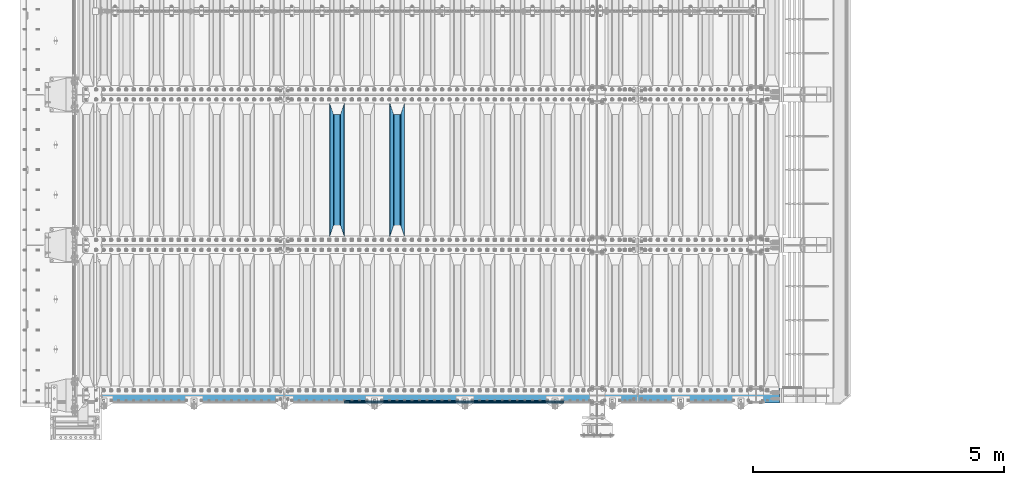
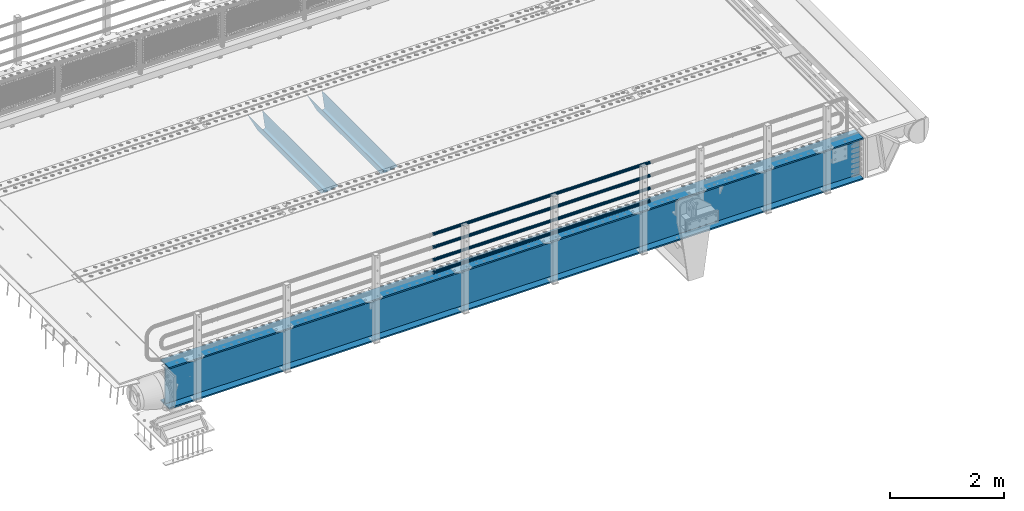
# One storey, part 100 of 219: 7 beams.
"""IFC2X3 building model written with IfcOpenShell, lengths in millimetres."""

from ifc_helpers import new_model, si_unit, frame, origin_with_axes, place, context, subcontext, project, spatial, faceted_brep, material, type_object, element, save


model = new_model("IFC2X3")

# Units and contexts
model_context = context("Model", 3, precision=1e-05, world=origin_with_axes())
body_context = subcontext(model_context, "Body", "Model", "MODEL_VIEW")
ifc_project = project(units=[si_unit("LENGTHUNIT", "METRE", prefix="MILLI"), si_unit("AREAUNIT", "SQUARE_METRE"), si_unit("VOLUMEUNIT", "CUBIC_METRE"), si_unit("MASSUNIT", "GRAM", prefix="KILO"), si_unit("TIMEUNIT", "SECOND"), si_unit("PLANEANGLEUNIT", "RADIAN"), si_unit("SOLIDANGLEUNIT", "STERADIAN"), si_unit("THERMODYNAMICTEMPERATUREUNIT", "DEGREE_CELSIUS"), si_unit("LUMINOUSINTENSITYUNIT", "LUMEN")], contexts=[model_context])

# Site, building, storey
site_placement = place(None, origin_with_axes())
site = spatial("IfcSite", under=ifc_project, at=site_placement, CompositionType="ELEMENT")
building_placement = place(site_placement, origin_with_axes())
building = spatial("IfcBuilding", under=site, at=building_placement, Name="Standard", CompositionType="ELEMENT")
storey_placement = place(building_placement, origin_with_axes())
storey = spatial("IfcBuildingStorey", under=building, at=storey_placement, Name="Undefined", CompositionType="ELEMENT", Elevation=0.0)

# Beams
ifc_material_1 = material(Name="STEEL/S355N")
beam_type_1 = type_object("IfcBeamType", PredefinedType="NOTDEFINED")
beam_1_placement = place(storey_placement, frame((6400.0, 27175.0, -115.0), z_axis=(0.0, 0.0, 1.0), x_axis=(0.0, 1.0, 0.0)))
element("IfcBeam", 1, at=beam_1_placement, inside=storey, type_object=beam_type_1, material=ifc_material_1, context=body_context, shape_type="Brep", body=[
    faceted_brep([(0.0, 150.0, 115.0), (0.0, 143.690000000001, 115.0), (2650.00000000297, 143.690000000001, 115.0), (2650.00000000297, 150.0, 115.0), (2650.00000000297, 142.0595652184, 110.000000003094), (2650.00000000297, 148.3695652184, 110.000000003094), (2441.90079219209, -80.110360073113, -98.0992078077845), (2437.7588105432, -77.5672621345566, -102.241189456673), (2434.06523489747, -74.4080125315541, -105.934765102404), (2430.9108609509, -70.7102721255742, -109.089139048974), (2428.37322971128, -66.5649389910068, -111.626770288588), (2426.51472138055, -62.0739139532889, -113.485278619323), (2425.38102192092, -57.3475956567672, -114.618978078955), (2424.99999999988, -52.5021667386536, -115.0), (2424.99999999988, 52.5021667386536, -115.0), (2425.38102192092, 57.3475956567672, -114.618978078955), (2426.51472138055, 62.0739139532889, -113.485278619323), (2428.37322971128, 66.5649389910068, -111.626770288588), (2430.9108609509, 70.7102721255742, -109.089139048974), (2434.06523489747, 74.4080125315541, -105.934765102404), (2437.7588105432, 77.5672621345566, -102.241189456673), (2441.90079219209, 80.110360073113, -98.0992078077846), (2446.38936140512, 81.9747917625791, -93.6106385947584), (2448.2494850041, 76.2713538057269, -91.7505149957729), (2444.62967112263, 74.7677798626082, -95.3703288772456), (2441.28936334127, 72.7168944282894, -98.710636658607), (2438.31067330439, 70.1691124903828, -101.689326695487), (2435.76682334748, 67.1870637758839, -104.233176652398), (2433.72034654134, 63.8440531834913, -106.279653458539), (2432.22154950042, 60.2222587982342, -107.778450499454), (2431.30727574265, 56.4107117849107, -108.692724257221), (2430.99999999987, 52.5031078186894, -109.0), (2430.99999999987, -52.5031078186894, -109.0), (2431.30727574265, -56.4107117849107, -108.692724257221), (2432.22154950042, -60.2222587982342, -107.778450499454), (2433.72034654134, -63.8440531834913, -106.279653458539), (2435.76682334748, -67.1870637758839, -104.233176652398), (2438.31067330439, -70.1691124903828, -101.689326695487), (2441.28936334127, -72.7168944282894, -98.7106366586071), (2444.62967112263, -74.7677798626082, -95.3703288772457), (2448.2494850041, -76.2713538057269, -91.7505149957729), (2650.00000000297, -142.0595652184, 110.000000003094), (2650.00000000297, -148.3695652184, 110.000000003094), (2446.38936140512, -81.9747917625791, -93.6106385947584), (2650.00000000297, -143.690000000001, 115.0), (2650.00000000297, -150.0, 115.0), (0.0, -143.690000000001, 115.0), (0.0, -150.0, 115.0), (0.0, -148.369565218261, 110.000000002667), (203.610638597427, -81.9747917625791, -93.6106385947584), (208.09920781045, -80.110360073113, -98.0992078077845), (212.241189459342, -77.5672621345566, -102.241189456673), (215.93476510507, -74.4080125315541, -105.934765102404), (219.089139051641, -70.7102721255742, -109.089139048974), (221.626770291256, -66.5649389910068, -111.626770288588), (223.485278621989, -62.0739139532889, -113.485278619323), (224.618978081624, -57.3475956567672, -114.618978078955), (225.000000002663, -52.5021667386536, -115.0), (225.000000002663, 52.5021667386536, -115.0), (224.618978081624, 57.3475956567672, -114.618978078955), (223.485278621989, 62.0739139532889, -113.485278619323), (221.626770291256, 66.5649389910068, -111.626770288588), (219.089139051641, 70.7102721255742, -109.089139048974), (215.93476510507, 74.4080125315541, -105.934765102404), (212.241189459342, 77.5672621345566, -102.241189456673), (208.09920781045, 80.110360073113, -98.0992078077846), (203.610638597427, 81.9747917625791, -93.6106385947584), (0.0, 148.369565218261, 110.000000002667), (0.0, 142.059565218262, 110.000000002667), (201.750514998439, 76.2713538057269, -91.7505149957729), (205.370328879915, 74.7677798626082, -95.3703288772456), (208.710636661275, 72.7168944282894, -98.710636658607), (211.689326698157, 70.1691124903828, -101.689326695487), (214.233176655063, 67.1870637758839, -104.233176652398), (216.279653461206, 63.8440531834913, -106.279653458539), (217.778450502123, 60.2222587982342, -107.778450499454), (218.69272425989, 56.4107117849107, -108.692724257221), (219.00000000267, 52.5031078186894, -109.0), (219.00000000267, -52.5031078186894, -109.0), (218.69272425989, -56.4107117849107, -108.692724257221), (217.778450502123, -60.2222587982342, -107.778450499454), (216.279653461206, -63.8440531834913, -106.279653458539), (214.233176655063, -67.1870637758839, -104.233176652398), (211.689326698157, -70.1691124903828, -101.689326695487), (208.710636661275, -72.7168944282894, -98.7106366586071), (205.370328879915, -74.7677798626082, -95.3703288772457), (201.750514998439, -76.2713538057269, -91.7505149957729), (0.0, -142.059565218262, 110.000000002667)], [[[0, 1, 2, 3]], [[3, 2, 4, 5]], [[6, 7, 8, 9, 10, 11, 12, 13, 14, 15, 16, 17, 18, 19, 20, 21, 22, 5, 4, 23, 24, 25, 26, 27, 28, 29, 30, 31, 32, 33, 34, 35, 36, 37, 38, 39, 40, 41, 42, 43]], [[44, 45, 42, 41]], [[46, 47, 45, 44]], [[43, 42, 45, 47, 48, 49]], [[6, 43, 49, 50]], [[7, 6, 50, 51]], [[8, 7, 51, 52]], [[9, 8, 52, 53]], [[10, 9, 53, 54]], [[11, 10, 54, 55]], [[12, 11, 55, 56]], [[13, 12, 56, 57]], [[14, 13, 57, 58]], [[15, 14, 58, 59]], [[16, 15, 59, 60]], [[17, 16, 60, 61]], [[18, 17, 61, 62]], [[19, 18, 62, 63]], [[20, 19, 63, 64]], [[21, 20, 64, 65]], [[22, 21, 65, 66]], [[0, 3, 5, 22, 66, 67]], [[1, 0, 67, 68]], [[23, 4, 2, 1, 68, 69]], [[24, 23, 69, 70]], [[25, 24, 70, 71]], [[26, 25, 71, 72]], [[27, 26, 72, 73]], [[28, 27, 73, 74]], [[29, 28, 74, 75]], [[30, 29, 75, 76]], [[31, 30, 76, 77]], [[32, 31, 77, 78]], [[33, 32, 78, 79]], [[34, 33, 79, 80]], [[35, 34, 80, 81]], [[36, 35, 81, 82]], [[37, 36, 82, 83]], [[38, 37, 83, 84]], [[39, 38, 84, 85]], [[40, 39, 85, 86]], [[46, 44, 41, 40, 86, 87]], [[47, 46, 87, 48]], [[86, 85, 84, 83, 82, 81, 80, 79, 78, 77, 76, 75, 74, 73, 72, 71, 70, 69, 68, 67, 66, 65, 64, 63, 62, 61, 60, 59, 58, 57, 56, 55, 54, 53, 52, 51, 50, 49, 48, 87]]]),
])
beam_2_placement = place(storey_placement, frame((5200.0, 27175.0, -115.0), z_axis=(0.0, 0.0, 1.0), x_axis=(0.0, 1.0, 0.0)))
element("IfcBeam", 2, at=beam_2_placement, inside=storey, type_object=beam_type_1, material=ifc_material_1, context=body_context, shape_type="Brep", body=[
    faceted_brep([(0.0, 150.0, 115.0), (0.0, 143.690000000001, 115.0), (2650.00000000297, 143.690000000001, 115.0), (2650.00000000297, 150.0, 115.0), (2650.00000000297, 142.0595652184, 110.000000003094), (2650.00000000297, 148.3695652184, 110.000000003094), (2441.90079219209, -80.110360073113, -98.0992078077845), (2437.7588105432, -77.5672621345566, -102.241189456673), (2434.06523489747, -74.4080125315541, -105.934765102404), (2430.9108609509, -70.7102721255742, -109.089139048974), (2428.37322971128, -66.5649389910068, -111.626770288588), (2426.51472138055, -62.0739139532889, -113.485278619323), (2425.38102192092, -57.3475956567672, -114.618978078955), (2424.99999999988, -52.5021667386536, -115.0), (2424.99999999988, 52.5021667386536, -115.0), (2425.38102192092, 57.3475956567672, -114.618978078955), (2426.51472138055, 62.0739139532889, -113.485278619323), (2428.37322971128, 66.5649389910068, -111.626770288588), (2430.9108609509, 70.7102721255742, -109.089139048974), (2434.06523489747, 74.4080125315541, -105.934765102404), (2437.7588105432, 77.5672621345566, -102.241189456673), (2441.90079219209, 80.110360073113, -98.0992078077846), (2446.38936140512, 81.9747917625791, -93.6106385947584), (2448.2494850041, 76.2713538057269, -91.7505149957729), (2444.62967112263, 74.7677798626082, -95.3703288772456), (2441.28936334127, 72.7168944282894, -98.710636658607), (2438.31067330439, 70.1691124903828, -101.689326695487), (2435.76682334748, 67.1870637758839, -104.233176652398), (2433.72034654134, 63.8440531834913, -106.279653458539), (2432.22154950042, 60.2222587982342, -107.778450499454), (2431.30727574265, 56.4107117849107, -108.692724257221), (2430.99999999987, 52.5031078186894, -109.0), (2430.99999999987, -52.5031078186894, -109.0), (2431.30727574265, -56.4107117849107, -108.692724257221), (2432.22154950042, -60.2222587982342, -107.778450499454), (2433.72034654134, -63.8440531834913, -106.279653458539), (2435.76682334748, -67.1870637758839, -104.233176652398), (2438.31067330439, -70.1691124903828, -101.689326695487), (2441.28936334127, -72.7168944282894, -98.7106366586071), (2444.62967112263, -74.7677798626082, -95.3703288772457), (2448.2494850041, -76.2713538057269, -91.7505149957729), (2650.00000000297, -142.0595652184, 110.000000003094), (2650.00000000297, -148.3695652184, 110.000000003094), (2446.38936140512, -81.9747917625791, -93.6106385947584), (2650.00000000297, -143.690000000001, 115.0), (2650.00000000297, -150.0, 115.0), (0.0, -143.690000000001, 115.0), (0.0, -150.0, 115.0), (0.0, -148.369565218261, 110.000000002667), (203.610638597427, -81.9747917625791, -93.6106385947584), (208.09920781045, -80.110360073113, -98.0992078077845), (212.241189459342, -77.5672621345566, -102.241189456673), (215.93476510507, -74.4080125315541, -105.934765102404), (219.089139051641, -70.7102721255742, -109.089139048974), (221.626770291256, -66.5649389910068, -111.626770288588), (223.485278621989, -62.0739139532889, -113.485278619323), (224.618978081624, -57.3475956567672, -114.618978078955), (225.000000002663, -52.5021667386536, -115.0), (225.000000002663, 52.5021667386536, -115.0), (224.618978081624, 57.3475956567672, -114.618978078955), (223.485278621989, 62.0739139532889, -113.485278619323), (221.626770291256, 66.5649389910068, -111.626770288588), (219.089139051641, 70.7102721255742, -109.089139048974), (215.93476510507, 74.4080125315541, -105.934765102404), (212.241189459342, 77.5672621345566, -102.241189456673), (208.09920781045, 80.110360073113, -98.0992078077846), (203.610638597427, 81.9747917625791, -93.6106385947584), (0.0, 148.369565218261, 110.000000002667), (0.0, 142.059565218262, 110.000000002667), (201.750514998439, 76.2713538057269, -91.7505149957729), (205.370328879915, 74.7677798626082, -95.3703288772456), (208.710636661275, 72.7168944282894, -98.710636658607), (211.689326698157, 70.1691124903828, -101.689326695487), (214.233176655063, 67.1870637758839, -104.233176652398), (216.279653461206, 63.8440531834913, -106.279653458539), (217.778450502123, 60.2222587982342, -107.778450499454), (218.69272425989, 56.4107117849107, -108.692724257221), (219.00000000267, 52.5031078186894, -109.0), (219.00000000267, -52.5031078186894, -109.0), (218.69272425989, -56.4107117849107, -108.692724257221), (217.778450502123, -60.2222587982342, -107.778450499454), (216.279653461206, -63.8440531834913, -106.279653458539), (214.233176655063, -67.1870637758839, -104.233176652398), (211.689326698157, -70.1691124903828, -101.689326695487), (208.710636661275, -72.7168944282894, -98.7106366586071), (205.370328879915, -74.7677798626082, -95.3703288772457), (201.750514998439, -76.2713538057269, -91.7505149957729), (0.0, -142.059565218262, 110.000000002667)], [[[0, 1, 2, 3]], [[3, 2, 4, 5]], [[6, 7, 8, 9, 10, 11, 12, 13, 14, 15, 16, 17, 18, 19, 20, 21, 22, 5, 4, 23, 24, 25, 26, 27, 28, 29, 30, 31, 32, 33, 34, 35, 36, 37, 38, 39, 40, 41, 42, 43]], [[44, 45, 42, 41]], [[46, 47, 45, 44]], [[43, 42, 45, 47, 48, 49]], [[6, 43, 49, 50]], [[7, 6, 50, 51]], [[8, 7, 51, 52]], [[9, 8, 52, 53]], [[10, 9, 53, 54]], [[11, 10, 54, 55]], [[12, 11, 55, 56]], [[13, 12, 56, 57]], [[14, 13, 57, 58]], [[15, 14, 58, 59]], [[16, 15, 59, 60]], [[17, 16, 60, 61]], [[18, 17, 61, 62]], [[19, 18, 62, 63]], [[20, 19, 63, 64]], [[21, 20, 64, 65]], [[22, 21, 65, 66]], [[0, 3, 5, 22, 66, 67]], [[1, 0, 67, 68]], [[23, 4, 2, 1, 68, 69]], [[24, 23, 69, 70]], [[25, 24, 70, 71]], [[26, 25, 71, 72]], [[27, 26, 72, 73]], [[28, 27, 73, 74]], [[29, 28, 74, 75]], [[30, 29, 75, 76]], [[31, 30, 76, 77]], [[32, 31, 77, 78]], [[33, 32, 78, 79]], [[34, 33, 79, 80]], [[35, 34, 80, 81]], [[36, 35, 81, 82]], [[37, 36, 82, 83]], [[38, 37, 83, 84]], [[39, 38, 84, 85]], [[40, 39, 85, 86]], [[46, 44, 41, 40, 86, 87]], [[47, 46, 87, 48]], [[86, 85, 84, 83, 82, 81, 80, 79, 78, 77, 76, 75, 74, 73, 72, 71, 70, 69, 68, 67, 66, 65, 64, 63, 62, 61, 60, 59, 58, 57, 56, 55, 54, 53, 52, 51, 50, 49, 48, 87]]]),
])
ifc_material_2 = material()
beam_type_2 = type_object("IfcBeamType", PredefinedType="NOTDEFINED")
beam_3_placement = place(storey_placement, frame((9727.99999999987, 23870.1500000001, 149.849999999748), z_axis=(0.0, 0.0, -1.0), x_axis=(-1.0, 0.0, 0.0)))
element("IfcBeam", 3, at=beam_3_placement, inside=storey, type_object=beam_type_2, material=ifc_material_2, context=body_context, shape_type="Brep", body=[
    faceted_brep([(0.0, -26.5500000000029, 0.0), (0.0, -24.5290015881765, 10.1602451292931), (4384.00249699992, -24.5290015881765, 10.1602451292931), (4384.00249699992, -26.5500000000029, 0.0), (0.0, -18.7736850405054, 18.7736850405028), (4384.00249699992, -18.7736850405054, 18.7736850405028), (0.0, -10.1602451292929, 24.5290015881747), (4384.00249699992, -10.1602451292929, 24.5290015881747), (0.0, 0.0, 26.55), (4384.00249699992, 0.0, 26.55), (0.0, 10.1602451292929, 24.5290015881747), (4384.00249699992, 10.1602451292929, 24.5290015881747), (0.0, 18.7736850405054, 18.7736850405028), (4384.00249699992, 18.7736850405054, 18.7736850405028), (0.0, 24.5290015881765, 10.1602451292931), (4384.00249699992, 24.5290015881765, 10.1602451292931), (0.0, 26.5500000000029, 0.0), (4384.00249699992, 26.5500000000029, 0.0), (0.0, 24.5290015881765, -10.1602451292931), (4384.00249699992, 24.5290015881765, -10.1602451292931), (0.0, 18.7736850405054, -18.7736850405028), (4384.00249699992, 18.7736850405054, -18.7736850405028), (0.0, 10.1602451292929, -24.5290015881747), (4384.00249699992, 10.1602451292929, -24.5290015881747), (0.0, 0.0, -26.55), (4384.00249699992, 0.0, -26.55), (0.0, -10.1602451292929, -24.5290015881747), (4384.00249699992, -10.1602451292929, -24.5290015881747), (0.0, -18.7736850405054, -18.7736850405028), (4384.00249699992, -18.7736850405054, -18.7736850405028), (0.0, -24.5290015881765, -10.1602451292931), (4384.00249699992, -24.5290015881765, -10.1602451292931), (0.0, -30.1500000000015, 0.0), (0.0, -27.8549679052157, -11.5379054858076), (4384.00249699992, -27.8549679052157, -11.5379054858075), (4384.00249699992, -30.1500000000015, 0.0), (0.0, -21.3192694527752, -21.3192694527752), (4384.00249699992, -21.3192694527752, -21.3192694527744), (0.0, -11.5379054858058, -27.8549679052157), (4384.00249699992, -11.5379054858058, -27.8549679052153), (0.0, 0.0, -30.1499999999996), (4384.00249699992, 0.0, -30.15), (0.0, 11.5379054858058, -27.8549679052157), (4384.00249699992, 11.5379054858058, -27.8549679052153), (0.0, 21.3192694527752, -21.3192694527752), (4384.00249699992, 21.3192694527752, -21.3192694527744), (0.0, 27.8549679052157, -11.5379054858076), (4384.00249699992, 27.8549679052157, -11.5379054858074), (0.0, 30.1500000000015, 0.0), (4384.00249699992, 30.1500000000015, 0.0), (0.0, 27.8549679052157, 11.5379054858076), (4384.00249699992, 27.8549679052157, 11.5379054858075), (0.0, 21.3192694527752, 21.3192694527752), (4384.00249699992, 21.3192694527752, 21.3192694527744), (0.0, 11.5379054858058, 27.8549679052157), (4384.00249699992, 11.5379054858058, 27.8549679052153), (0.0, 0.0, 30.1499999999996), (4384.00249699992, 0.0, 30.15), (0.0, -11.5379054858058, 27.8549679052157), (4384.00249699992, -11.5379054858058, 27.8549679052153), (0.0, -21.3192694527752, 21.3192694527752), (4384.00249699992, -21.3192694527752, 21.3192694527744), (0.0, -27.8549679052157, 11.5379054858076), (4384.00249699992, -27.8549679052157, 11.5379054858075)], [[[0, 1, 2, 3]], [[1, 4, 5, 2]], [[4, 6, 7, 5]], [[6, 8, 9, 7]], [[8, 10, 11, 9]], [[10, 12, 13, 11]], [[12, 14, 15, 13]], [[14, 16, 17, 15]], [[16, 18, 19, 17]], [[18, 20, 21, 19]], [[20, 22, 23, 21]], [[22, 24, 25, 23]], [[24, 26, 27, 25]], [[26, 28, 29, 27]], [[28, 30, 31, 29]], [[30, 0, 3, 31]], [[32, 33, 34, 35]], [[33, 36, 37, 34]], [[36, 38, 39, 37]], [[38, 40, 41, 39]], [[40, 42, 43, 41]], [[42, 44, 45, 43]], [[44, 46, 47, 45]], [[46, 48, 49, 47]], [[48, 50, 51, 49]], [[50, 52, 53, 51]], [[52, 54, 55, 53]], [[54, 56, 57, 55]], [[56, 58, 59, 57]], [[58, 60, 61, 59]], [[60, 62, 63, 61]], [[62, 32, 35, 63]], [[37, 39, 41, 43, 45, 47, 49, 51, 53, 55, 57, 59, 61, 63, 35, 34], [5, 7, 9, 11, 13, 15, 17, 19, 21, 23, 25, 27, 29, 31, 3, 2]], [[62, 60, 58, 56, 54, 52, 50, 48, 46, 44, 42, 40, 38, 36, 33, 32], [30, 28, 26, 24, 22, 20, 18, 16, 14, 12, 10, 8, 6, 4, 1, 0]]]),
])
beam_4_placement = place(storey_placement, frame((9727.99999999987, 23870.1500000001, 420.149999999748), z_axis=(0.0, 0.0, -1.0), x_axis=(-1.0, 0.0, 0.0)))
element("IfcBeam", 4, at=beam_4_placement, inside=storey, type_object=beam_type_2, material=ifc_material_2, context=body_context, shape_type="Brep", body=[
    faceted_brep([(0.0, -26.5500000000029, 0.0), (0.0, -24.5290015881765, 10.1602451292931), (4384.00249699992, -24.5290015881765, 10.1602451292931), (4384.00249699992, -26.5500000000029, 0.0), (0.0, -18.7736850405054, 18.7736850405028), (4384.00249699992, -18.7736850405054, 18.7736850405028), (0.0, -10.1602451292929, 24.5290015881747), (4384.00249699992, -10.1602451292929, 24.5290015881747), (0.0, 0.0, 26.55), (4384.00249699992, 0.0, 26.55), (0.0, 10.1602451292929, 24.5290015881747), (4384.00249699992, 10.1602451292929, 24.5290015881747), (0.0, 18.7736850405054, 18.7736850405028), (4384.00249699992, 18.7736850405054, 18.7736850405028), (0.0, 24.5290015881765, 10.1602451292931), (4384.00249699992, 24.5290015881765, 10.1602451292931), (0.0, 26.5500000000029, 0.0), (4384.00249699992, 26.5500000000029, 0.0), (0.0, 24.5290015881765, -10.1602451292931), (4384.00249699992, 24.5290015881765, -10.1602451292931), (0.0, 18.7736850405054, -18.7736850405028), (4384.00249699992, 18.7736850405054, -18.7736850405028), (0.0, 10.1602451292929, -24.5290015881747), (4384.00249699992, 10.1602451292929, -24.5290015881747), (0.0, 0.0, -26.55), (4384.00249699992, 0.0, -26.55), (0.0, -10.1602451292929, -24.5290015881747), (4384.00249699992, -10.1602451292929, -24.5290015881747), (0.0, -18.7736850405054, -18.7736850405028), (4384.00249699992, -18.7736850405054, -18.7736850405028), (0.0, -24.5290015881765, -10.1602451292931), (4384.00249699992, -24.5290015881765, -10.1602451292931), (0.0, -30.1500000000015, 0.0), (0.0, -27.8549679052157, -11.5379054858076), (4384.00249699992, -27.8549679052157, -11.5379054858075), (4384.00249699992, -30.1500000000015, 0.0), (0.0, -21.3192694527752, -21.3192694527752), (4384.00249699992, -21.3192694527752, -21.3192694527744), (0.0, -11.5379054858058, -27.8549679052157), (4384.00249699992, -11.5379054858058, -27.8549679052153), (0.0, 0.0, -30.1499999999996), (4384.00249699992, 0.0, -30.15), (0.0, 11.5379054858058, -27.8549679052157), (4384.00249699992, 11.5379054858058, -27.8549679052153), (0.0, 21.3192694527752, -21.3192694527752), (4384.00249699992, 21.3192694527752, -21.3192694527744), (0.0, 27.8549679052157, -11.5379054858076), (4384.00249699992, 27.8549679052157, -11.5379054858074), (0.0, 30.1500000000015, 0.0), (4384.00249699992, 30.1500000000015, 0.0), (0.0, 27.8549679052157, 11.5379054858076), (4384.00249699992, 27.8549679052157, 11.5379054858075), (0.0, 21.3192694527752, 21.3192694527752), (4384.00249699992, 21.3192694527752, 21.3192694527744), (0.0, 11.5379054858058, 27.8549679052157), (4384.00249699992, 11.5379054858058, 27.8549679052153), (0.0, 0.0, 30.1499999999996), (4384.00249699992, 0.0, 30.15), (0.0, -11.5379054858058, 27.8549679052157), (4384.00249699992, -11.5379054858058, 27.8549679052153), (0.0, -21.3192694527752, 21.3192694527752), (4384.00249699992, -21.3192694527752, 21.3192694527744), (0.0, -27.8549679052157, 11.5379054858076), (4384.00249699992, -27.8549679052157, 11.5379054858075)], [[[0, 1, 2, 3]], [[1, 4, 5, 2]], [[4, 6, 7, 5]], [[6, 8, 9, 7]], [[8, 10, 11, 9]], [[10, 12, 13, 11]], [[12, 14, 15, 13]], [[14, 16, 17, 15]], [[16, 18, 19, 17]], [[18, 20, 21, 19]], [[20, 22, 23, 21]], [[22, 24, 25, 23]], [[24, 26, 27, 25]], [[26, 28, 29, 27]], [[28, 30, 31, 29]], [[30, 0, 3, 31]], [[32, 33, 34, 35]], [[33, 36, 37, 34]], [[36, 38, 39, 37]], [[38, 40, 41, 39]], [[40, 42, 43, 41]], [[42, 44, 45, 43]], [[44, 46, 47, 45]], [[46, 48, 49, 47]], [[48, 50, 51, 49]], [[50, 52, 53, 51]], [[52, 54, 55, 53]], [[54, 56, 57, 55]], [[56, 58, 59, 57]], [[58, 60, 61, 59]], [[60, 62, 63, 61]], [[62, 32, 35, 63]], [[37, 39, 41, 43, 45, 47, 49, 51, 53, 55, 57, 59, 61, 63, 35, 34], [5, 7, 9, 11, 13, 15, 17, 19, 21, 23, 25, 27, 29, 31, 3, 2]], [[62, 60, 58, 56, 54, 52, 50, 48, 46, 44, 42, 40, 38, 36, 33, 32], [30, 28, 26, 24, 22, 20, 18, 16, 14, 12, 10, 8, 6, 4, 1, 0]]]),
])
beam_5_placement = place(storey_placement, frame((9727.99999999987, 23870.1500000001, 969.849999999748), z_axis=(0.0, 0.0, -1.0), x_axis=(-1.0, 0.0, 0.0)))
element("IfcBeam", 5, at=beam_5_placement, inside=storey, type_object=beam_type_2, material=ifc_material_2, context=body_context, shape_type="Brep", body=[
    faceted_brep([(0.0, -26.5500000000029, 0.0), (0.0, -24.5290015881765, 10.1602451292931), (4384.00249699992, -24.5290015881765, 10.1602451292931), (4384.00249699992, -26.5500000000029, 0.0), (0.0, -18.7736850405054, 18.7736850405028), (4384.00249699992, -18.7736850405054, 18.7736850405028), (0.0, -10.1602451292929, 24.5290015881747), (4384.00249699992, -10.1602451292929, 24.5290015881747), (0.0, 0.0, 26.55), (4384.00249699992, 0.0, 26.55), (0.0, 10.1602451292929, 24.5290015881747), (4384.00249699992, 10.1602451292929, 24.5290015881747), (0.0, 18.7736850405054, 18.7736850405028), (4384.00249699992, 18.7736850405054, 18.7736850405028), (0.0, 24.5290015881765, 10.1602451292931), (4384.00249699992, 24.5290015881765, 10.1602451292931), (0.0, 26.5500000000029, 0.0), (4384.00249699992, 26.5500000000029, 0.0), (0.0, 24.5290015881765, -10.1602451292931), (4384.00249699992, 24.5290015881765, -10.1602451292931), (0.0, 18.7736850405054, -18.7736850405028), (4384.00249699992, 18.7736850405054, -18.7736850405028), (0.0, 10.1602451292929, -24.5290015881747), (4384.00249699992, 10.1602451292929, -24.5290015881747), (0.0, 0.0, -26.55), (4384.00249699992, 0.0, -26.55), (0.0, -10.1602451292929, -24.5290015881747), (4384.00249699992, -10.1602451292929, -24.5290015881747), (0.0, -18.7736850405054, -18.7736850405028), (4384.00249699992, -18.7736850405054, -18.7736850405028), (0.0, -24.5290015881765, -10.1602451292931), (4384.00249699992, -24.5290015881765, -10.1602451292931), (0.0, -30.1500000000015, 0.0), (0.0, -27.8549679052157, -11.5379054858076), (4384.00249699992, -27.8549679052157, -11.5379054858075), (4384.00249699992, -30.1500000000015, 0.0), (0.0, -21.3192694527752, -21.3192694527752), (4384.00249699992, -21.3192694527752, -21.3192694527744), (0.0, -11.5379054858058, -27.8549679052157), (4384.00249699992, -11.5379054858058, -27.8549679052153), (0.0, 0.0, -30.1499999999996), (4384.00249699992, 0.0, -30.15), (0.0, 11.5379054858058, -27.8549679052157), (4384.00249699992, 11.5379054858058, -27.8549679052153), (0.0, 21.3192694527752, -21.3192694527752), (4384.00249699992, 21.3192694527752, -21.3192694527744), (0.0, 27.8549679052157, -11.5379054858076), (4384.00249699992, 27.8549679052157, -11.5379054858074), (0.0, 30.1500000000015, 0.0), (4384.00249699992, 30.1500000000015, 0.0), (0.0, 27.8549679052157, 11.5379054858076), (4384.00249699992, 27.8549679052157, 11.5379054858075), (0.0, 21.3192694527752, 21.3192694527752), (4384.00249699992, 21.3192694527752, 21.3192694527744), (0.0, 11.5379054858058, 27.8549679052157), (4384.00249699992, 11.5379054858058, 27.8549679052153), (0.0, 0.0, 30.1499999999996), (4384.00249699992, 0.0, 30.15), (0.0, -11.5379054858058, 27.8549679052157), (4384.00249699992, -11.5379054858058, 27.8549679052153), (0.0, -21.3192694527752, 21.3192694527752), (4384.00249699992, -21.3192694527752, 21.3192694527744), (0.0, -27.8549679052157, 11.5379054858076), (4384.00249699992, -27.8549679052157, 11.5379054858075)], [[[0, 1, 2, 3]], [[1, 4, 5, 2]], [[4, 6, 7, 5]], [[6, 8, 9, 7]], [[8, 10, 11, 9]], [[10, 12, 13, 11]], [[12, 14, 15, 13]], [[14, 16, 17, 15]], [[16, 18, 19, 17]], [[18, 20, 21, 19]], [[20, 22, 23, 21]], [[22, 24, 25, 23]], [[24, 26, 27, 25]], [[26, 28, 29, 27]], [[28, 30, 31, 29]], [[30, 0, 3, 31]], [[32, 33, 34, 35]], [[33, 36, 37, 34]], [[36, 38, 39, 37]], [[38, 40, 41, 39]], [[40, 42, 43, 41]], [[42, 44, 45, 43]], [[44, 46, 47, 45]], [[46, 48, 49, 47]], [[48, 50, 51, 49]], [[50, 52, 53, 51]], [[52, 54, 55, 53]], [[54, 56, 57, 55]], [[56, 58, 59, 57]], [[58, 60, 61, 59]], [[60, 62, 63, 61]], [[62, 32, 35, 63]], [[37, 39, 41, 43, 45, 47, 49, 51, 53, 55, 57, 59, 61, 63, 35, 34], [5, 7, 9, 11, 13, 15, 17, 19, 21, 23, 25, 27, 29, 31, 3, 2]], [[62, 60, 58, 56, 54, 52, 50, 48, 46, 44, 42, 40, 38, 36, 33, 32], [30, 28, 26, 24, 22, 20, 18, 16, 14, 12, 10, 8, 6, 4, 1, 0]]]),
])
beam_6_placement = place(storey_placement, frame((9727.99999999987, 23870.1500000001, 689.849999999748), z_axis=(0.0, 0.0, -1.0), x_axis=(-1.0, 0.0, 0.0)))
element("IfcBeam", 6, at=beam_6_placement, inside=storey, type_object=beam_type_2, material=ifc_material_2, context=body_context, shape_type="Brep", body=[
    faceted_brep([(0.0, -26.5500000000029, 0.0), (0.0, -24.5290015881765, 10.1602451292931), (4384.00249699992, -24.5290015881765, 10.1602451292931), (4384.00249699992, -26.5500000000029, 0.0), (0.0, -18.7736850405054, 18.7736850405028), (4384.00249699992, -18.7736850405054, 18.7736850405028), (0.0, -10.1602451292929, 24.5290015881747), (4384.00249699992, -10.1602451292929, 24.5290015881747), (0.0, 0.0, 26.55), (4384.00249699992, 0.0, 26.55), (0.0, 10.1602451292929, 24.5290015881747), (4384.00249699992, 10.1602451292929, 24.5290015881747), (0.0, 18.7736850405054, 18.7736850405028), (4384.00249699992, 18.7736850405054, 18.7736850405028), (0.0, 24.5290015881765, 10.1602451292931), (4384.00249699992, 24.5290015881765, 10.1602451292931), (0.0, 26.5500000000029, 0.0), (4384.00249699992, 26.5500000000029, 0.0), (0.0, 24.5290015881765, -10.1602451292931), (4384.00249699992, 24.5290015881765, -10.1602451292931), (0.0, 18.7736850405054, -18.7736850405028), (4384.00249699992, 18.7736850405054, -18.7736850405028), (0.0, 10.1602451292929, -24.5290015881747), (4384.00249699992, 10.1602451292929, -24.5290015881747), (0.0, 0.0, -26.55), (4384.00249699992, 0.0, -26.55), (0.0, -10.1602451292929, -24.5290015881747), (4384.00249699992, -10.1602451292929, -24.5290015881747), (0.0, -18.7736850405054, -18.7736850405028), (4384.00249699992, -18.7736850405054, -18.7736850405028), (0.0, -24.5290015881765, -10.1602451292931), (4384.00249699992, -24.5290015881765, -10.1602451292931), (0.0, -30.1500000000015, 0.0), (0.0, -27.8549679052157, -11.5379054858076), (4384.00249699992, -27.8549679052157, -11.5379054858075), (4384.00249699992, -30.1500000000015, 0.0), (0.0, -21.3192694527752, -21.3192694527752), (4384.00249699992, -21.3192694527752, -21.3192694527744), (0.0, -11.5379054858058, -27.8549679052157), (4384.00249699992, -11.5379054858058, -27.8549679052153), (0.0, 0.0, -30.1499999999996), (4384.00249699992, 0.0, -30.15), (0.0, 11.5379054858058, -27.8549679052157), (4384.00249699992, 11.5379054858058, -27.8549679052153), (0.0, 21.3192694527752, -21.3192694527752), (4384.00249699992, 21.3192694527752, -21.3192694527744), (0.0, 27.8549679052157, -11.5379054858076), (4384.00249699992, 27.8549679052157, -11.5379054858074), (0.0, 30.1500000000015, 0.0), (4384.00249699992, 30.1500000000015, 0.0), (0.0, 27.8549679052157, 11.5379054858076), (4384.00249699992, 27.8549679052157, 11.5379054858075), (0.0, 21.3192694527752, 21.3192694527752), (4384.00249699992, 21.3192694527752, 21.3192694527744), (0.0, 11.5379054858058, 27.8549679052157), (4384.00249699992, 11.5379054858058, 27.8549679052153), (0.0, 0.0, 30.1499999999996), (4384.00249699992, 0.0, 30.15), (0.0, -11.5379054858058, 27.8549679052157), (4384.00249699992, -11.5379054858058, 27.8549679052153), (0.0, -21.3192694527752, 21.3192694527752), (4384.00249699992, -21.3192694527752, 21.3192694527744), (0.0, -27.8549679052157, 11.5379054858076), (4384.00249699992, -27.8549679052157, 11.5379054858075)], [[[0, 1, 2, 3]], [[1, 4, 5, 2]], [[4, 6, 7, 5]], [[6, 8, 9, 7]], [[8, 10, 11, 9]], [[10, 12, 13, 11]], [[12, 14, 15, 13]], [[14, 16, 17, 15]], [[16, 18, 19, 17]], [[18, 20, 21, 19]], [[20, 22, 23, 21]], [[22, 24, 25, 23]], [[24, 26, 27, 25]], [[26, 28, 29, 27]], [[28, 30, 31, 29]], [[30, 0, 3, 31]], [[32, 33, 34, 35]], [[33, 36, 37, 34]], [[36, 38, 39, 37]], [[38, 40, 41, 39]], [[40, 42, 43, 41]], [[42, 44, 45, 43]], [[44, 46, 47, 45]], [[46, 48, 49, 47]], [[48, 50, 51, 49]], [[50, 52, 53, 51]], [[52, 54, 55, 53]], [[54, 56, 57, 55]], [[56, 58, 59, 57]], [[58, 60, 61, 59]], [[60, 62, 63, 61]], [[62, 32, 35, 63]], [[37, 39, 41, 43, 45, 47, 49, 51, 53, 55, 57, 59, 61, 63, 35, 34], [5, 7, 9, 11, 13, 15, 17, 19, 21, 23, 25, 27, 29, 31, 3, 2]], [[62, 60, 58, 56, 54, 52, 50, 48, 46, 44, 42, 40, 38, 36, 33, 32], [30, 28, 26, 24, 22, 20, 18, 16, 14, 12, 10, 8, 6, 4, 1, 0]]]),
])
beam_type_3 = type_object("IfcBeamType", Name="HEA900", PredefinedType="NOTDEFINED")
beam_7_placement = place(storey_placement, frame((10.0, 24000.0, -445.0), z_axis=(0.0, 0.0, 1.0), x_axis=(1.0, 0.0, 0.0)))
element("IfcBeam", 7, at=beam_7_placement, inside=storey, type_object=beam_type_3, material=ifc_material_1, ObjectType="HEA900", context=body_context, shape_type="Brep", body=[
    faceted_brep([(0.0, 150.0, -445.0), (0.0, 150.0, -415.0), (14017.0, 150.0, -415.0), (14017.0, 150.0, -445.0), (0.0, 8.0, -415.0), (14017.0, 8.0, -415.0), (0.0, 8.0, 415.0), (14017.0, 8.0, 415.0), (0.0, 150.0, 415.0), (14017.0, 150.0, 415.0), (0.0, 150.0, 445.0), (14017.0, 150.0, 445.0), (0.0, -150.0, 445.0), (14017.0, -150.0, 445.0), (0.0, -150.0, 415.0), (14017.0, -150.0, 415.0), (0.0, -8.0, 415.0), (14017.0, -8.0, 415.0), (0.0, -8.0, -415.0), (14017.0, -8.0, -415.0), (0.0, -150.0, -415.0), (14017.0, -150.0, -415.0), (0.0, -150.0, -445.0), (14017.0, -150.0, -445.0)], [[[0, 1, 2, 3]], [[1, 4, 5, 2]], [[4, 6, 7, 5]], [[6, 8, 9, 7]], [[8, 10, 11, 9]], [[10, 12, 13, 11]], [[12, 14, 15, 13]], [[14, 16, 17, 15]], [[16, 18, 19, 17]], [[18, 20, 21, 19]], [[20, 22, 23, 21]], [[22, 0, 3, 23]], [[5, 7, 9, 11, 13, 15, 17, 19, 21, 23, 3, 2]], [[22, 20, 18, 16, 14, 12, 10, 8, 6, 4, 1, 0]]]),
])

save(model, "model.ifc")
